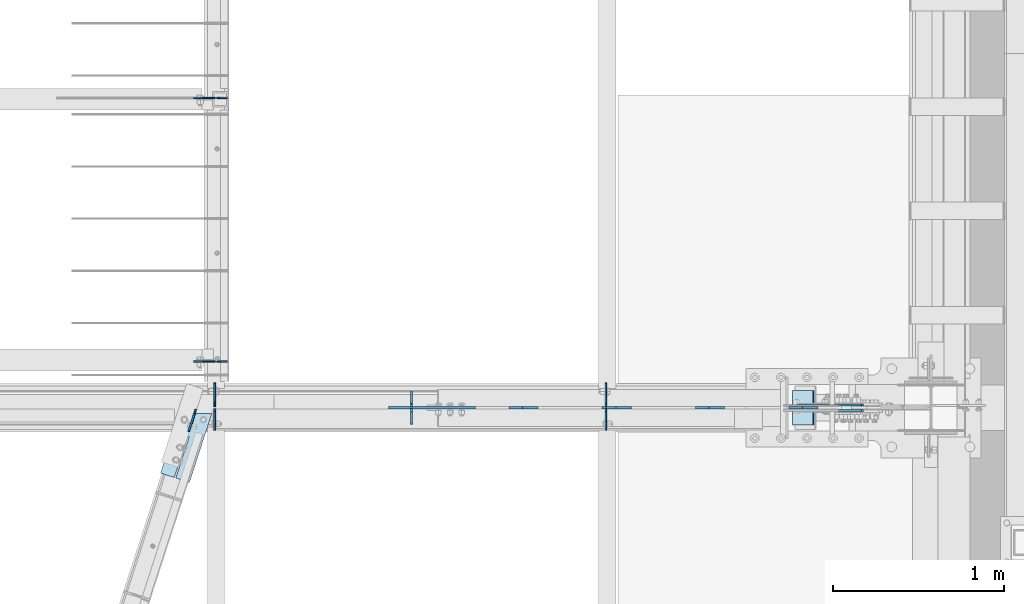
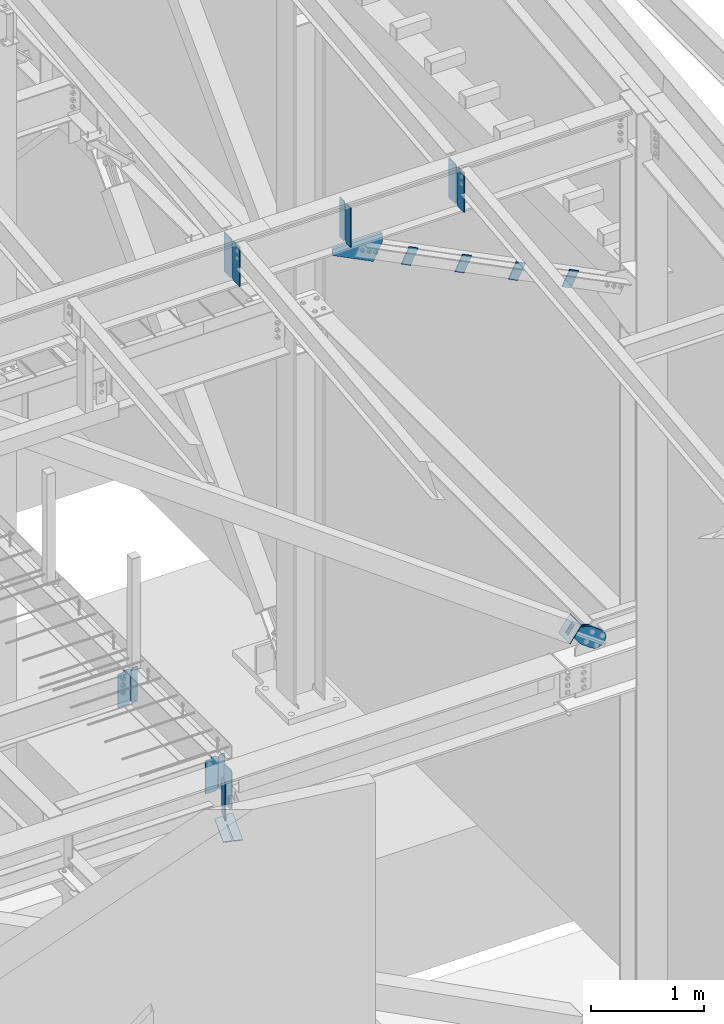
# One storey, part 1002 of 1179: 21 plates, 8 elements without a shape of their own.
"""IFC2X3 building model written with IfcOpenShell, lengths in millimetres."""

from ifc_helpers import new_model, si_unit, frame, origin_with_axes, place, context, subcontext, project, spatial, faceted_brep, material, type_object, element, aggregate, save


model = new_model("IFC2X3")

# Units and contexts
model_context = context("Model", 3, precision=1e-05, world=origin_with_axes())
body_context = subcontext(model_context, "Body", "Model", "MODEL_VIEW")
ifc_project = project(units=[si_unit("LENGTHUNIT", "METRE", prefix="MILLI"), si_unit("AREAUNIT", "SQUARE_METRE"), si_unit("VOLUMEUNIT", "CUBIC_METRE"), si_unit("MASSUNIT", "GRAM", prefix="KILO"), si_unit("TIMEUNIT", "SECOND"), si_unit("PLANEANGLEUNIT", "RADIAN"), si_unit("SOLIDANGLEUNIT", "STERADIAN"), si_unit("THERMODYNAMICTEMPERATUREUNIT", "DEGREE_CELSIUS"), si_unit("LUMINOUSINTENSITYUNIT", "LUMEN")], contexts=[model_context])

# Site, building, storey
site_placement = place(None, origin_with_axes())
site = spatial("IfcSite", under=ifc_project, at=site_placement, CompositionType="ELEMENT")
building_placement = place(site_placement, origin_with_axes())
building = spatial("IfcBuilding", under=site, at=building_placement, Name="Undefined", CompositionType="ELEMENT")
storey_placement = place(building_placement, origin_with_axes())
storey = spatial("IfcBuildingStorey", under=building, at=storey_placement, Name="Undefined", CompositionType="ELEMENT", Elevation=0.0)

# Assembly, plates
assembly_1_placement = place(storey_placement, origin_with_axes())
assembly_1 = element("IfcElementAssembly", 1, at=assembly_1_placement, inside=storey, Name="BEAM", AssemblyPlace="NOTDEFINED", PredefinedType="RIGID_FRAME")
ifc_material = material(Name="STEEL/A36")
plate_type_1 = type_object("IfcPlateType", PredefinedType="NOTDEFINED")
plate_1_placement = place(assembly_1_placement, frame((20126.325, 5707.06200008392, 3711.575), z_axis=(0.0, 0.0, 1.0), x_axis=(-1.0, 0.0, 0.0)))
plate_1 = element("IfcPlate", 2, at=plate_1_placement, type_object=plate_type_1, material=ifc_material, Name="PLATE", context=body_context, shape_type="Brep", body=[
    faceted_brep([(66.6743865212811, -4.76249999999709, 377.825), (66.6745864763507, -4.76249999999709, 371.474599924168), (66.6745876193563, 4.76249999999709, 371.474599924203), (66.6743876643031, 4.76249999999709, 377.825), (67.6414311678836, -4.76249999999709, 366.614643208318), (67.6414323108893, 4.76249999999709, 366.614643208353), (70.3944716748138, -4.76249999999709, 362.494602443389), (70.3944728178176, 4.76249999999709, 362.494602443423), (74.5145991226364, -4.76249999999709, 359.741691665477), (74.514600265642, 4.76249999999709, 359.741691665511), (79.3745862790947, -4.76249999999709, 358.774999999796), (79.3745874221004, 4.76249999999709, 358.774999999831), (127.000000004868, -4.76249999999709, 358.774999992755), (127.0, 4.76249999999709, 358.774999992755), (0.0, -4.76249999999709, 358.775000762939), (19.0499992370605, -4.76249999999709, 377.825), (19.0499992370605, 4.76249999999709, 377.825), (0.0, 4.76249999999709, 358.775000762939), (0.0, -4.76250000000073, 19.0499992370605), (0.0, 4.76250000000073, 19.0499992370605), (19.0499992370605, -4.76250000000073, 0.0), (19.0499992370605, 4.76250000000073, 0.0), (127.0, -4.76250000000073, 0.0), (127.0, 4.76250000000073, 0.0)], [[[0, 1, 2, 3]], [[4, 5, 2, 1]], [[6, 7, 5, 4]], [[8, 9, 7, 6]], [[10, 11, 9, 8]], [[12, 13, 11, 10]], [[14, 15, 16, 17]], [[18, 14, 17, 19]], [[20, 18, 19, 21]], [[22, 20, 21, 23]], [[8, 6, 4, 1, 0, 15, 14, 18, 20, 22, 12, 10]], [[16, 15, 0, 3]], [[23, 21, 19, 17, 16, 3, 2, 5, 7, 9, 11, 13]], [[22, 23, 13, 12]]]),
])
plate_2_placement = place(assembly_1_placement, frame((20126.325, 7246.93799991608, 3711.575), z_axis=(0.0, 0.0, 1.0), x_axis=(-1.0, 0.0, 0.0)))
plate_2 = element("IfcPlate", 3, at=plate_2_placement, type_object=plate_type_1, material=ifc_material, Name="PLATE", context=body_context, shape_type="Brep", body=[
    faceted_brep([(66.6743865212811, -4.76249999999709, 377.825), (66.6745864763507, -4.76249999999709, 371.474599924168), (66.6745876193563, 4.76249999999709, 371.474599924203), (66.6743876643031, 4.76249999999709, 377.825), (67.6414311678836, -4.76249999999709, 366.614643208318), (67.6414323108893, 4.76249999999709, 366.614643208353), (70.3944716748138, -4.76249999999709, 362.494602443389), (70.3944728178176, 4.76249999999709, 362.494602443423), (74.5145991226364, -4.76249999999709, 359.741691665477), (74.514600265642, 4.76249999999709, 359.741691665511), (79.3745862790947, -4.76249999999709, 358.774999999796), (79.3745874221004, 4.76249999999709, 358.774999999831), (127.000000004868, -4.76249999999709, 358.774999992755), (127.0, 4.76249999999709, 358.774999992755), (0.0, -4.76249999999709, 358.775000762939), (19.0499992370605, -4.76249999999709, 377.825), (19.0499992370605, 4.76249999999709, 377.825), (0.0, 4.76249999999709, 358.775000762939), (0.0, -4.76250000000073, 19.0499992370605), (0.0, 4.76250000000073, 19.0499992370605), (19.0499992370605, -4.76250000000073, 0.0), (19.0499992370605, 4.76250000000073, 0.0), (127.0, -4.76250000000073, 0.0), (127.0, 4.76250000000073, 0.0)], [[[0, 1, 2, 3]], [[4, 5, 2, 1]], [[6, 7, 5, 4]], [[8, 9, 7, 6]], [[10, 11, 9, 8]], [[12, 13, 11, 10]], [[14, 15, 16, 17]], [[18, 14, 17, 19]], [[20, 18, 19, 21]], [[22, 20, 21, 23]], [[8, 6, 4, 1, 0, 15, 14, 18, 20, 22, 12, 10]], [[16, 15, 0, 3]], [[23, 21, 19, 17, 16, 3, 2, 5, 7, 9, 11, 13]], [[22, 23, 13, 12]]]),
])

assembly_2_placement = place(storey_placement, origin_with_axes())
assembly_2 = element("IfcElementAssembly", 4, at=assembly_2_placement, inside=storey, Name="BEAM", AssemblyPlace="NOTDEFINED", PredefinedType="RIGID_FRAME")
plate_3_placement = place(assembly_2_placement, frame((20122.3557500839, 5430.05308465637, 9380.8287842795), z_axis=(0.0, 0.0, 1.0), x_axis=(0.0, -1.0, 0.0)))
plate_3 = element("IfcPlate", 5, at=plate_3_placement, type_object=plate_type_1, material=ifc_material, Name="PLATE", context=body_context, shape_type="Brep", body=[
    faceted_brep([(-1.81898940354586e-12, -4.76249999999345, 17.4624996185303), (0.0, -4.76250000000073, 407.98750038147), (0.0, 4.76250000000073, 407.98750038147), (1.81898940354586e-12, 4.76250000000073, 17.4624996185303), (17.4624996185303, -4.76250000000073, 425.450000000001), (17.4624996185303, 4.76250000000073, 425.450000000001), (127.0, -4.76250000000073, 425.450000000001), (127.0, 4.76250000000073, 425.450000000001), (127.0, -4.76250000000073, 0.0), (127.0, 4.76250000000073, 0.0), (17.4624996185157, -4.76250000000073, 0.0), (17.4624996185212, 4.76249999999345, 0.0)], [[[0, 1, 2, 3]], [[1, 4, 5, 2]], [[4, 6, 7, 5]], [[6, 8, 9, 7]], [[8, 10, 11, 9]], [[10, 0, 3, 11]], [[5, 7, 9, 11, 3, 2]], [[10, 8, 6, 4, 1, 0]]]),
])
plate_4_placement = place(assembly_2_placement, frame((22408.3557500839, 5430.05308465637, 9380.8287842795), z_axis=(0.0, 0.0, 1.0), x_axis=(0.0, -1.0, 0.0)))
plate_4 = element("IfcPlate", 6, at=plate_4_placement, type_object=plate_type_1, material=ifc_material, Name="PLATE", context=body_context, shape_type="Brep", body=[
    faceted_brep([(-1.81898940354586e-12, -4.76249999999345, 17.4624996185303), (0.0, -4.76250000000073, 407.98750038147), (0.0, 4.76250000000073, 407.98750038147), (1.81898940354586e-12, 4.76250000000073, 17.4624996185303), (17.4624996185303, -4.76250000000073, 425.450000000001), (17.4624996185303, 4.76250000000073, 425.450000000001), (127.0, -4.76250000000073, 425.450000000001), (127.0, 4.76250000000073, 425.450000000001), (127.0, -4.76250000000073, 0.0), (127.0, 4.76250000000073, 0.0), (17.4624996185157, -4.76250000000073, 0.0), (17.4624996185212, 4.76249999999345, 0.0)], [[[0, 1, 2, 3]], [[1, 4, 5, 2]], [[4, 6, 7, 5]], [[6, 8, 9, 7]], [[8, 10, 11, 9]], [[10, 0, 3, 11]], [[5, 7, 9, 11, 3, 2]], [[10, 8, 6, 4, 1, 0]]]),
])

# Assembly, plate
assembly_3_placement = place(storey_placement, origin_with_axes())
assembly_3 = element("IfcElementAssembly", 7, at=assembly_3_placement, inside=storey, Name="BEAM", AssemblyPlace="NOTDEFINED", PredefinedType="RIGID_FRAME")
plate_type_2 = type_object("IfcPlateType", PredefinedType="NOTDEFINED")
plate_5_placement = place(assembly_3_placement, frame((20121.5620000839, 5442.74375, 3652.8375), z_axis=(0.0, 0.0, 1.0), x_axis=(0.0, 1.0, 0.0)))
plate_5 = element("IfcPlate", 8, at=plate_5_placement, type_object=plate_type_2, material=ifc_material, Name="PLATE", context=body_context, shape_type="Brep", body=[
    faceted_brep([(0.0, -4.76250000000073, 25.3999996185303), (9.09494701772928e-13, -4.76250000000073, 400.05000038147), (2.72848410531878e-12, 4.76249999999891, 400.05000038147), (0.0, 4.76250000000073, 25.3999996185303), (25.3999996185312, -4.76250000000709, 425.45), (25.399999618533, 4.76249999999254, 425.45), (134.937500000001, -4.76250000003438, 425.45), (134.937500000003, 4.76249999996526, 425.45), (134.937500000001, -4.76250000003438, 0.0), (134.937500000003, 4.76249999996526, 0.0), (25.3999996185303, -4.76250000000073, 0.0), (25.3999996185303, 4.76250000000073, 0.0)], [[[0, 1, 2, 3]], [[1, 4, 5, 2]], [[4, 6, 7, 5]], [[6, 8, 9, 7]], [[8, 10, 11, 9]], [[10, 0, 3, 11]], [[5, 7, 9, 11, 3, 2]], [[10, 8, 6, 4, 1, 0]]]),
])

# Plate
plate_type_3 = type_object("IfcPlateType", PredefinedType="NOTDEFINED")
plate_6_placement = place(assembly_2_placement, frame((21272.5, 5338.77183465637, 9379.2412842795), z_axis=(0.0, 0.0, 1.0), x_axis=(0.0, 1.0, 0.0)))
plate_6 = element("IfcPlate", 9, at=plate_6_placement, type_object=plate_type_3, material=ifc_material, Name="PLATE", context=body_context, shape_type="Brep", body=[
    faceted_brep([(0.0, -4.76249999999709, 0.0), (0.0, -4.76250000000073, 428.625), (0.0, 4.76250000000073, 428.625), (0.0, 4.76249999999709, 0.0), (72.2312507629395, -4.76250000000073, 428.625), (72.2312507629395, 4.76250000000073, 428.625), (91.28125, -4.76250000000073, 409.575000762939), (91.28125, 4.76250000000073, 409.575000762939), (91.28125, -4.76250000000073, 19.0499992370605), (91.28125, 4.76250000000073, 19.0499992370605), (72.2312502153181, -4.76249999999709, 0.0), (72.2312502153181, 4.76249999999709, 0.0)], [[[0, 1, 2, 3]], [[1, 4, 5, 2]], [[4, 6, 7, 5]], [[6, 8, 9, 7]], [[8, 10, 11, 9]], [[10, 0, 3, 11]], [[5, 7, 9, 11, 3, 2]], [[10, 8, 6, 4, 1, 0]]]),
])

plate_7_placement = place(assembly_2_placement, frame((21272.5, 5441.16558465636, 9379.2412842795), z_axis=(0.0, 0.0, 1.0), x_axis=(0.0, 1.0, 0.0)))
plate_7 = element("IfcPlate", 10, at=plate_7_placement, type_object=plate_type_3, material=ifc_material, Name="PLATE", context=body_context, shape_type="Brep", body=[
    faceted_brep([(0.0, -4.76250000000073, 19.0499992370605), (0.0, -4.76250000000073, 409.575000762939), (0.0, 4.76250000000073, 409.575000762939), (0.0, 4.76250000000073, 19.0499992370605), (19.0499992370605, -4.76250000000073, 428.625), (19.0499992370605, 4.76250000000073, 428.625), (91.28125, -4.76250000000073, 428.625), (91.28125, 4.76250000000073, 428.625), (91.28125, -4.76250000000073, 0.0), (91.28125, 4.76250000000073, 0.0), (19.0499992370605, -4.76250000000073, 0.0), (19.0499992370605, 4.76250000000073, 0.0)], [[[0, 1, 2, 3]], [[1, 4, 5, 2]], [[4, 6, 7, 5]], [[6, 8, 9, 7]], [[8, 10, 11, 9]], [[10, 0, 3, 11]], [[5, 7, 9, 11, 3, 2]], [[10, 8, 6, 4, 1, 0]]]),
])

# Assembly, plate
assembly_4_placement = place(storey_placement, origin_with_axes())
assembly_4 = element("IfcElementAssembly", 11, at=assembly_4_placement, inside=storey, Name="Plate", AssemblyPlace="NOTDEFINED", PredefinedType="RIGID_FRAME")
plate_type_4 = type_object("IfcPlateType", PredefinedType="NOTDEFINED")
plate_8_placement = place(assembly_4_placement, frame((23501.0831647072, 5334.0, 4328.53301899354), z_axis=(0.589511681969932, 0.0, 0.807759850958799), x_axis=(0.0, 1.0, 0.0)))
plate_8 = element("IfcPlate", 12, at=plate_8_placement, type_object=plate_type_4, material=ifc_material, Name="Plate", context=body_context, shape_type="Brep", body=[
    faceted_brep([(0.0, -3.17500000000109, 0.0), (0.0, -3.17500000000291, 203.200000000368), (0.0, 3.17499999998836, 203.200000000361), (0.0, 3.17500000000109, 7.27595761418343e-12), (203.199999999997, -3.17500000000291, 203.200000000368), (203.199999999997, 3.17499999998836, 203.200000000361), (203.199999999997, -3.17499999999927, 3.63797880709171e-12), (203.199999999997, 3.17499999999382, -3.63797880709171e-12)], [[[0, 1, 2, 3]], [[1, 4, 5, 2]], [[4, 6, 7, 5]], [[6, 0, 3, 7]], [[5, 7, 3, 2]], [[6, 4, 1, 0]]]),
])
aggregate(assembly_4, [plate_8])

# Plate
plate_type_5 = type_object("IfcPlateType", PredefinedType="NOTDEFINED")
plate_9_placement = place(assembly_2_placement, frame((20122.3557500839, 5441.16558465636, 9380.8287842795), z_axis=(0.0, 0.0, 1.0), x_axis=(0.0, 1.0, 0.0)))
plate_9 = element("IfcPlate", 13, at=plate_9_placement, type_object=plate_type_5, material=ifc_material, Name="PLATE", context=body_context, shape_type="Brep", body=[
    faceted_brep([(-1.81898940354586e-12, -4.76249999999345, 17.4624996185303), (0.0, -4.76250000000073, 407.98750038147), (0.0, 4.76250000000073, 407.98750038147), (1.81898940354586e-12, 4.76250000000073, 17.4624996185303), (17.4624996185303, -4.76250000000073, 425.450000000001), (17.4624996185303, 4.76250000000073, 425.450000000001), (139.699999999997, -4.76250000000073, 425.450000000001), (139.699999999997, 4.76250000000073, 425.450000000001), (139.7, -4.76249999999982, 0.0), (139.7, 4.76249999999982, 0.0), (17.4624996185157, -4.76250000000073, 0.0), (17.4624996185212, 4.76249999999345, 0.0)], [[[0, 1, 2, 3]], [[1, 4, 5, 2]], [[4, 6, 7, 5]], [[6, 8, 9, 7]], [[8, 10, 11, 9]], [[10, 0, 3, 11]], [[5, 7, 9, 11, 3, 2]], [[10, 8, 6, 4, 1, 0]]]),
])

plate_10_placement = place(assembly_2_placement, frame((22408.3557500839, 5441.16558465636, 9380.8287842795), z_axis=(0.0, 0.0, 1.0), x_axis=(0.0, 1.0, 0.0)))
plate_10 = element("IfcPlate", 14, at=plate_10_placement, type_object=plate_type_5, material=ifc_material, Name="PLATE", context=body_context, shape_type="Brep", body=[
    faceted_brep([(-1.81898940354586e-12, -4.76249999999345, 17.4624996185303), (0.0, -4.76250000000073, 407.98750038147), (0.0, 4.76250000000073, 407.98750038147), (1.81898940354586e-12, 4.76250000000073, 17.4624996185303), (17.4624996185303, -4.76250000000073, 425.450000000001), (17.4624996185303, 4.76250000000073, 425.450000000001), (139.699999999997, -4.76250000000073, 425.450000000001), (139.699999999997, 4.76250000000073, 425.450000000001), (139.7, -4.76249999999982, 0.0), (139.7, 4.76249999999982, 0.0), (17.4624996185157, -4.76250000000073, 0.0), (17.4624996185212, 4.76249999999345, 0.0)], [[[0, 1, 2, 3]], [[1, 4, 5, 2]], [[4, 6, 7, 5]], [[6, 8, 9, 7]], [[8, 10, 11, 9]], [[10, 0, 3, 11]], [[5, 7, 9, 11, 3, 2]], [[10, 8, 6, 4, 1, 0]]]),
])

# Assembly, plates
assembly_5_placement = place(storey_placement, origin_with_axes())
assembly_5 = element("IfcElementAssembly", 15, at=assembly_5_placement, inside=storey, Name="ANGLE", AssemblyPlace="NOTDEFINED", PredefinedType="RIGID_FRAME")
plate_type_6 = type_object("IfcPlateType", PredefinedType="NOTDEFINED")
plate_11_placement = place(assembly_5_placement, frame((21932.8303395021, 5435.59999999782, 8898.76629630632), z_axis=(-0.894434265088011, 0.0, 0.447199447044012), x_axis=(0.447199447044011, 0.0, 0.894434265088011)))
plate_11 = element("IfcPlate", 16, at=plate_11_placement, type_object=plate_type_6, material=ifc_material, Name="PLATE", context=body_context, shape_type="Brep", body=[
    faceted_brep([(0.0, -6.34999999999854, 0.0), (-1.30967237055302e-09, -6.35000000000036, 101.600000000462), (-1.30967237055302e-09, 6.35000000000036, 101.600000000462), (0.0, 6.34999999999854, 0.0), (177.728045790594, -6.35000000000036, 101.600000000493), (177.728045790594, 6.35000000000036, 101.600000000493), (177.728045791871, -6.35000000000036, -2.36468622460961e-11), (177.728045791871, 6.35000000000036, -2.36468622460961e-11)], [[[0, 1, 2, 3]], [[1, 4, 5, 2]], [[4, 6, 7, 5]], [[6, 0, 3, 7]], [[5, 7, 3, 2]], [[6, 4, 1, 0]]]),
])
plate_12_placement = place(assembly_5_placement, frame((22478.026776898, 5435.5999999997, 8626.05212817568), z_axis=(-0.894434265088011, 0.0, 0.447199447044012), x_axis=(0.447199447044011, 0.0, 0.894434265088011)))
plate_12 = element("IfcPlate", 17, at=plate_12_placement, type_object=plate_type_6, material=ifc_material, Name="PLATE", context=body_context, shape_type="Brep", body=[
    faceted_brep([(0.0, -6.34999999999854, 0.0), (-1.30967237055302e-09, -6.35000000000036, 101.600000000462), (-1.30967237055302e-09, 6.35000000000036, 101.600000000462), (0.0, 6.34999999999854, 0.0), (177.728045790594, -6.35000000000036, 101.600000000493), (177.728045790594, 6.35000000000036, 101.600000000493), (177.728045791871, -6.35000000000036, -2.36468622460961e-11), (177.728045791871, 6.35000000000036, -2.36468622460961e-11)], [[[0, 1, 2, 3]], [[1, 4, 5, 2]], [[4, 6, 7, 5]], [[6, 0, 3, 7]], [[5, 7, 3, 2]], [[6, 4, 1, 0]]]),
])
plate_13_placement = place(assembly_5_placement, frame((23023.2739074047, 5435.5999999997, 8353.43935027635), z_axis=(-0.894434265088011, 0.0, 0.447199447044012), x_axis=(0.447199447044011, 0.0, 0.894434265088011)))
plate_13 = element("IfcPlate", 18, at=plate_13_placement, type_object=plate_type_6, material=ifc_material, Name="PLATE", context=body_context, shape_type="Brep", body=[
    faceted_brep([(0.0, -6.34999999999854, 0.0), (-1.30967237055302e-09, -6.35000000000036, 101.600000000462), (-1.30967237055302e-09, 6.35000000000036, 101.600000000462), (0.0, 6.34999999999854, 0.0), (177.728045790594, -6.35000000000036, 101.600000000493), (177.728045790594, 6.35000000000036, 101.600000000493), (177.728045791871, -6.35000000000036, -2.36468622460961e-11), (177.728045791871, 6.35000000000036, -2.36468622460961e-11)], [[[0, 1, 2, 3]], [[1, 4, 5, 2]], [[4, 6, 7, 5]], [[6, 0, 3, 7]], [[5, 7, 3, 2]], [[6, 4, 1, 0]]]),
])
plate_14_placement = place(assembly_5_placement, frame((23568.5717240273, 5435.5999999997, 8080.92794861651), z_axis=(-0.894434265088011, 0.0, 0.447199447044012), x_axis=(0.447199447044011, 0.0, 0.894434265088011)))
plate_14 = element("IfcPlate", 19, at=plate_14_placement, type_object=plate_type_6, material=ifc_material, Name="PLATE", context=body_context, shape_type="Brep", body=[
    faceted_brep([(0.0, -6.34999999999854, 0.0), (-1.30967237055302e-09, -6.35000000000036, 101.600000000462), (-1.30967237055302e-09, 6.35000000000036, 101.600000000462), (0.0, 6.34999999999854, 0.0), (177.728045790594, -6.35000000000036, 101.600000000493), (177.728045790594, 6.35000000000036, 101.600000000493), (177.728045791871, -6.35000000000036, -2.36468622460961e-11), (177.728045791871, 6.35000000000036, -2.36468622460961e-11)], [[[0, 1, 2, 3]], [[1, 4, 5, 2]], [[4, 6, 7, 5]], [[6, 0, 3, 7]], [[5, 7, 3, 2]], [[6, 4, 1, 0]]]),
])
aggregate(assembly_5, [plate_11, plate_12, plate_13, plate_14])

# Plate
plate_type_7 = type_object("IfcPlateType", PredefinedType="NOTDEFINED")
plate_15_placement = place(assembly_2_placement, frame((21136.9816692991, 5435.6, 9360.19128427958), z_axis=(0.0, 0.0, -1.0), x_axis=(1.0, 0.0, 0.0)))
plate_15 = element("IfcPlate", 20, at=plate_15_placement, type_object=plate_type_7, material=ifc_material, Name="PLATE", context=body_context, shape_type="Brep", body=[
    faceted_brep([(508.523792556298, 6.35000000000036, 12.6999999999571), (508.523792556298, -6.35000000000036, 0.0), (0.0, -6.34999999999854, 0.0), (0.0, 6.35000000000036, 12.6999999999571), (0.0, -6.35000000000036, 76.2000000000044), (417.652864383315, -6.35000000000036, 286.660206994229), (417.652864383315, 6.35000000000036, 286.660206994229), (0.0, 6.35000000000036, 76.2000000000044), (508.523792556298, -6.35000000000036, 104.911163261024), (508.523792556298, 6.35000000000036, 104.911163261024)], [[[0, 1, 2, 3]], [[4, 5, 6, 7]], [[5, 8, 9, 6]], [[7, 6, 9, 0, 3]], [[4, 7, 3, 2]], [[8, 5, 4, 2, 1]], [[9, 8, 1, 0]]]),
])

aggregate(assembly_2, [plate_6, plate_7, plate_15, plate_9, plate_10, plate_3, plate_4])

# Assembly, plate
assembly_6_placement = place(storey_placement, origin_with_axes())
assembly_6 = element("IfcElementAssembly", 21, at=assembly_6_placement, inside=storey, Name="BEAM", AssemblyPlace="NOTDEFINED", PredefinedType="RIGID_FRAME")
plate_type_8 = type_object("IfcPlateType", PredefinedType="NOTDEFINED")
plate_16_placement = place(assembly_6_placement, frame((20105.8011801609, 5403.05638865122, 3656.0125), z_axis=(0.0, -1.0, 0.0), x_axis=(-1.0, 0.0, 0.0)))
plate_16 = element("IfcPlate", 22, at=plate_16_placement, type_object=plate_type_8, material=ifc_material, Name="PLATE", context=body_context, shape_type="Brep", body=[
    faceted_brep([(211.216107923115, -4.76249999999982, 378.186292958948), (132.955849109949, -4.76249999999982, 137.084613413418), (132.955849109949, 4.76249999999982, 137.084613413418), (211.216107923115, 4.76249999999982, 378.186292958948), (142.015527764503, -4.76249999999982, 134.143892343771), (142.015527764503, 4.76249999999982, 134.143892343771), (220.275785761864, -4.76249999999982, 375.245572460486), (220.275785761864, 4.76249999999982, 375.245572460486), (0.0, -4.76249999999709, 0.0), (131.188949585219, -4.76249999999982, 404.162658691443), (131.188949585219, 4.76249999999982, 404.162658691443), (0.0, 4.76249999999709, 0.0), (186.932113647461, -4.76249999999982, 1.81898940354586e-12), (186.932113647461, 4.76249999999982, 1.81898940354586e-12), (300.302978515847, -4.76249999999982, 349.269195556723), (300.302978515847, 4.76249999999982, 349.269195556723)], [[[0, 1, 2, 3]], [[4, 5, 2, 1]], [[6, 7, 5, 4]], [[8, 9, 10, 11]], [[12, 8, 11, 13]], [[14, 12, 13, 15]], [[1, 0, 9, 8, 12, 14, 6, 4]], [[10, 9, 0, 3]], [[15, 13, 11, 10, 3, 2, 5, 7]], [[14, 15, 7, 6]]]),
])
aggregate(assembly_6, [plate_16])

# Plate
plate_type_9 = type_object("IfcPlateType", PredefinedType="NOTDEFINED")
plate_17_placement = place(assembly_1_placement, frame((20132.675, 5707.06200008392, 3711.575), z_axis=(0.0, 0.0, 1.0), x_axis=(1.0, 0.0, 0.0)))
plate_17 = element("IfcPlate", 23, at=plate_17_placement, type_object=plate_type_9, material=ifc_material, Name="PLATE", context=body_context, shape_type="Brep", body=[
    faceted_brep([(0.0, -4.76250000000073, 19.0499992370605), (0.0, -4.76249999999709, 358.775000762939), (0.0, 4.76249999999709, 358.775000762939), (0.0, 4.76250000000073, 19.0499992370605), (19.0499992370605, -4.76249999999709, 377.825), (19.0499992370605, 4.76249999999709, 377.825), (63.5, -4.76250000000073, 377.825012207031), (63.5, 4.76250000000073, 377.825012207031), (63.5, -4.76250000000073, 0.0), (63.5, 4.76250000000073, 0.0), (19.0499992370605, -4.76250000000073, 0.0), (19.0499992370605, 4.76250000000073, 0.0)], [[[0, 1, 2, 3]], [[1, 4, 5, 2]], [[4, 6, 7, 5]], [[6, 8, 9, 7]], [[8, 10, 11, 9]], [[10, 0, 3, 11]], [[5, 7, 9, 11, 3, 2]], [[10, 8, 6, 4, 1, 0]]]),
])

plate_18_placement = place(assembly_1_placement, frame((20132.675, 7246.93799991608, 3711.575), z_axis=(0.0, 0.0, 1.0), x_axis=(1.0, 0.0, 0.0)))
plate_18 = element("IfcPlate", 24, at=plate_18_placement, type_object=plate_type_9, material=ifc_material, Name="PLATE", context=body_context, shape_type="Brep", body=[
    faceted_brep([(0.0, -4.76250000000073, 19.0499992370605), (0.0, -4.76249999999709, 358.775000762939), (0.0, 4.76249999999709, 358.775000762939), (0.0, 4.76250000000073, 19.0499992370605), (19.0499992370605, -4.76249999999709, 377.825), (19.0499992370605, 4.76249999999709, 377.825), (63.5, -4.76250000000073, 377.825012207031), (63.5, 4.76250000000073, 377.825012207031), (63.5, -4.76250000000073, 0.0), (63.5, 4.76250000000073, 0.0), (19.0499992370605, -4.76250000000073, 0.0), (19.0499992370605, 4.76250000000073, 0.0)], [[[0, 1, 2, 3]], [[1, 4, 5, 2]], [[4, 6, 7, 5]], [[6, 8, 9, 7]], [[8, 10, 11, 9]], [[10, 0, 3, 11]], [[5, 7, 9, 11, 3, 2]], [[10, 8, 6, 4, 1, 0]]]),
])

aggregate(assembly_1, [plate_17, plate_1, plate_18, plate_2])

# Assembly, plate
assembly_7_placement = place(storey_placement, origin_with_axes())
assembly_7 = element("IfcElementAssembly", 25, at=assembly_7_placement, inside=storey, AssemblyPlace="NOTDEFINED", PredefinedType="RIGID_FRAME")
plate_type_10 = type_object("IfcPlateType", PredefinedType="NOTDEFINED")
plate_19_placement = place(assembly_7_placement, frame((23525.3457504462, 5451.475, 4367.16387794497), z_axis=(0.589511681969932, 0.0, 0.807759850958799), x_axis=(0.807759850958799, 0.0, -0.589511681969932)))
plate_19 = element("IfcPlate", 26, at=plate_19_placement, type_object=plate_type_10, material=ifc_material, context=body_context, shape_type="Brep", body=[
    faceted_brep([(0.0, -6.34999999999854, 0.0), (-4.35647962149233e-10, -6.34999999999854, 112.184930806416), (-4.35647962149233e-10, 6.34999999999854, 112.184930806416), (0.0, 6.34999999999854, 0.0), (80.0100000001657, -6.35000000000036, 112.184930806456), (80.0100000001657, 6.35000000000036, 112.184930806456), (181.610000000368, -6.35000000000036, 149.754965403412), (181.610000000368, 6.35000000000036, 149.754965403412), (325.379242324256, -6.35000000000036, 149.754965403416), (325.379242324256, 6.35000000000036, 149.754965403416), (361.22232872423, -6.35000000000036, 142.625332233401), (361.22232872423, 6.35000000000036, 142.625332233401), (391.608630138198, -6.35000000000036, 122.321854743212), (391.608630138198, 6.35000000000036, 122.321854743212), (411.912107628388, -6.35000000000036, 91.9355533292437), (411.912107628388, 6.35000000000036, 91.9355533292437), (419.041740798395, -6.35000000000036, 56.0924638771867), (419.041740798395, 6.35000000000036, 56.0924638771867), (411.912107628381, -6.35000000000036, 20.2493774772083), (411.912107628381, 6.35000000000036, 20.2493774772083), (391.608630138195, -6.35000000000036, -10.1369239367559), (391.608630138195, 6.35000000000036, -10.1369239367559), (361.222328724227, -6.35000000000036, -30.4404014269494), (361.222328724227, 6.35000000000036, -30.4404014269494), (325.379240798207, -6.35000000000036, -37.5700345969635), (325.379240798207, 6.35000000000036, -37.5700345969635), (181.610000000361, -6.35000000000036, -37.5700345969672), (181.610000000361, 6.35000000000036, -37.5700345969672), (80.0100000001621, -6.35000000000036, 0.0), (80.0100000001621, 6.35000000000036, 0.0)], [[[0, 1, 2, 3]], [[1, 4, 5, 2]], [[4, 6, 7, 5]], [[6, 8, 9, 7]], [[8, 10, 11, 9]], [[10, 12, 13, 11]], [[12, 14, 15, 13]], [[14, 16, 17, 15]], [[16, 18, 19, 17]], [[18, 20, 21, 19]], [[20, 22, 23, 21]], [[22, 24, 25, 23]], [[24, 26, 27, 25]], [[26, 28, 29, 27]], [[28, 0, 3, 29]], [[5, 7, 9, 11, 13, 15, 17, 19, 21, 23, 25, 27, 29, 3, 2]], [[28, 26, 24, 22, 20, 18, 16, 14, 12, 10, 8, 6, 4, 1, 0]]]),
])
aggregate(assembly_7, [plate_19])

assembly_8_placement = place(storey_placement, origin_with_axes())
assembly_8 = element("IfcElementAssembly", 27, at=assembly_8_placement, inside=storey, AssemblyPlace="NOTDEFINED", PredefinedType="RIGID_FRAME")
plate_20_placement = place(assembly_8_placement, frame((23525.3457504462, 5419.725, 4367.16387794497), z_axis=(0.589511681969932, 0.0, 0.807759850958799), x_axis=(0.807759850958799, 0.0, -0.589511681969932)))
plate_20 = element("IfcPlate", 28, at=plate_20_placement, type_object=plate_type_10, material=ifc_material, context=body_context, shape_type="Brep", body=[
    faceted_brep([(0.0, -6.34999999999854, 0.0), (-4.35647962149233e-10, -6.34999999999854, 112.184930806416), (-4.35647962149233e-10, 6.34999999999854, 112.184930806416), (0.0, 6.34999999999854, 0.0), (80.0100000001657, -6.35000000000036, 112.184930806456), (80.0100000001657, 6.35000000000036, 112.184930806456), (181.610000000368, -6.35000000000036, 149.754965403412), (181.610000000368, 6.35000000000036, 149.754965403412), (325.379242324256, -6.35000000000036, 149.754965403416), (325.379242324256, 6.35000000000036, 149.754965403416), (361.22232872423, -6.35000000000036, 142.625332233401), (361.22232872423, 6.35000000000036, 142.625332233401), (391.608630138198, -6.35000000000036, 122.321854743212), (391.608630138198, 6.35000000000036, 122.321854743212), (411.912107628388, -6.35000000000036, 91.9355533292437), (411.912107628388, 6.35000000000036, 91.9355533292437), (419.041740798395, -6.35000000000036, 56.0924638771867), (419.041740798395, 6.35000000000036, 56.0924638771867), (411.912107628381, -6.35000000000036, 20.2493774772083), (411.912107628381, 6.35000000000036, 20.2493774772083), (391.608630138195, -6.35000000000036, -10.1369239367559), (391.608630138195, 6.35000000000036, -10.1369239367559), (361.222328724227, -6.35000000000036, -30.4404014269494), (361.222328724227, 6.35000000000036, -30.4404014269494), (325.379240798207, -6.35000000000036, -37.5700345969635), (325.379240798207, 6.35000000000036, -37.5700345969635), (181.610000000361, -6.35000000000036, -37.5700345969672), (181.610000000361, 6.35000000000036, -37.5700345969672), (80.0100000001621, -6.35000000000036, 0.0), (80.0100000001621, 6.35000000000036, 0.0)], [[[0, 1, 2, 3]], [[1, 4, 5, 2]], [[4, 6, 7, 5]], [[6, 8, 9, 7]], [[8, 10, 11, 9]], [[10, 12, 13, 11]], [[12, 14, 15, 13]], [[14, 16, 17, 15]], [[16, 18, 19, 17]], [[18, 20, 21, 19]], [[20, 22, 23, 21]], [[22, 24, 25, 23]], [[24, 26, 27, 25]], [[26, 28, 29, 27]], [[28, 0, 3, 29]], [[5, 7, 9, 11, 13, 15, 17, 19, 21, 23, 25, 27, 29, 3, 2]], [[28, 26, 24, 22, 20, 18, 16, 14, 12, 10, 8, 6, 4, 1, 0]]]),
])
aggregate(assembly_8, [plate_20])

# Plate
plate_type_11 = type_object("IfcPlateType", PredefinedType="NOTDEFINED")
plate_21_placement = place(assembly_3_placement, frame((19969.1695857596, 5295.78286085767, 3683.00001220703), z_axis=(0.0, 0.0, 1.0), x_axis=(0.308737244064257, 0.951147367197958, 0.0)))
plate_21 = element("IfcPlate", 29, at=plate_21_placement, type_object=plate_type_11, material=ifc_material, Name="PLATE", context=body_context, shape_type="Brep", body=[
    faceted_brep([(0.0, -4.76249999999709, 0.0), (1.81898940354586e-12, -4.76250000000437, 396.875), (0.0, 4.762500000008, 396.875), (0.0, 4.76249999999709, 0.0), (112.541818618729, -4.76249999994252, 396.875), (112.541818618723, 4.76250000007713, 396.875), (137.941818237248, -4.76249999992433, 371.47500038147), (137.941818237246, 4.76250000009168, 371.47500038147), (137.941818237248, -4.76249999992433, 0.0), (137.941818237246, 4.76250000009168, 0.0)], [[[0, 1, 2, 3]], [[1, 4, 5, 2]], [[4, 6, 7, 5]], [[6, 8, 9, 7]], [[8, 0, 3, 9]], [[5, 7, 9, 3, 2]], [[8, 6, 4, 1, 0]]]),
])

aggregate(assembly_3, [plate_21, plate_5])

save(model, "model.ifc")
